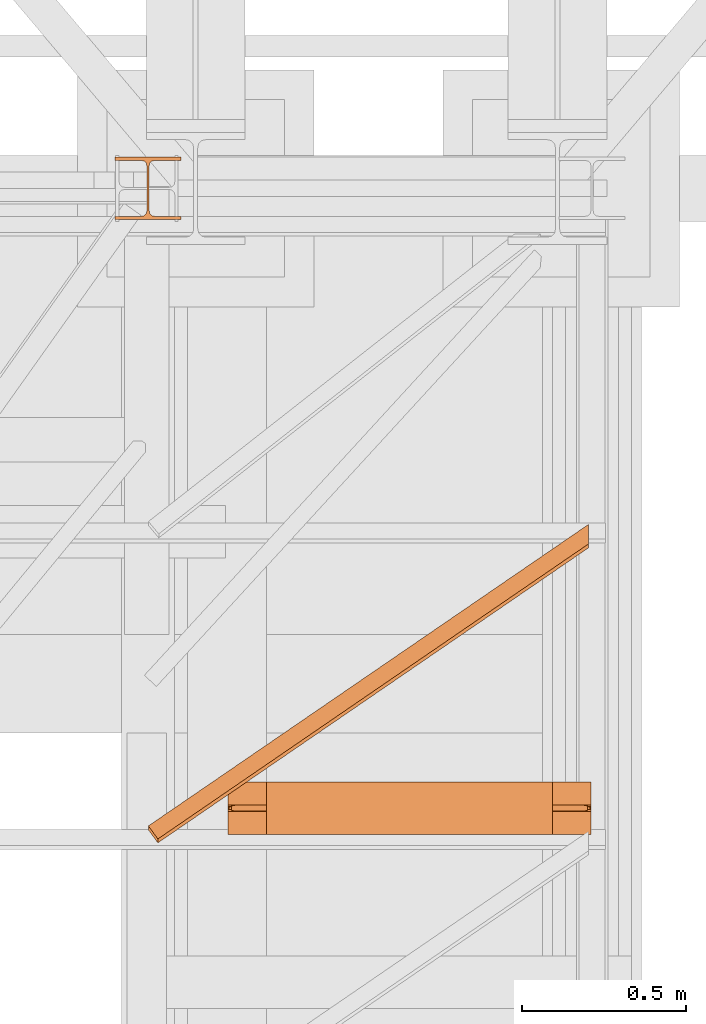
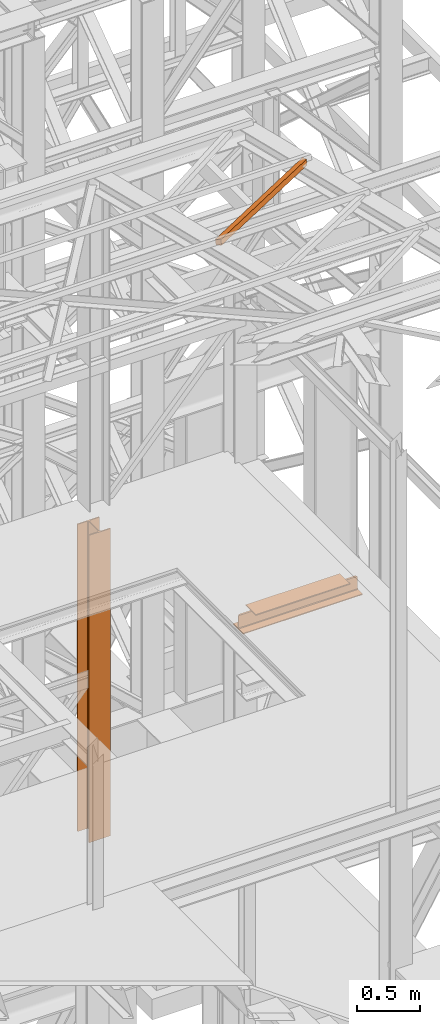
# One storey, part 76 of 208: 3 proxies.
"""IFC2X3 building model written with IfcOpenShell, lengths in millimetres."""

from ifc_helpers import new_model, entity, si_unit, converted_unit, frame, origin, origin_with_axes, place, context, subcontext, project, spatial, faceted_brep, element, save


model = new_model("IFC2X3")

# Units and contexts
model_context = context("Model", 3, precision=1e-05, world=origin())
plan_context = context("Plan", 3, precision=1e-05, world=origin())
body_context = subcontext(model_context, "Body", "Model", "MODEL_VIEW")
ifc_project = project(units=[si_unit("LENGTHUNIT", "METRE", prefix="MILLI"), converted_unit("PLANEANGLEUNIT", "DEGREE", entity("IfcPlaneAngleMeasure", 0.0174532925199433), si_unit("PLANEANGLEUNIT", "RADIAN"), dimensions=[0, 0, 0, 0, 0, 0, 0]), si_unit("AREAUNIT", "SQUARE_METRE"), si_unit("VOLUMEUNIT", "CUBIC_METRE")], contexts=[model_context, plan_context])

# Building, storey
building_placement = place(None, origin())
building = spatial("IfcBuilding", under=ifc_project, at=building_placement, CompositionType="COMPLEX")
storey_placement = place(building_placement, origin_with_axes())
storey = spatial("IfcBuildingStorey", under=building, at=storey_placement, Name="Geschoss", CompositionType="ELEMENT")

# Proxies
proxy_1_placement = place(storey_placement, frame((5349.415251226797, -19252.42762679125, 11987.74979641016), z_axis=(0.0, 0.0, 1.0), x_axis=(1.0, 0.0, 0.0)))
element("IfcBuildingElementProxy", 1, at=proxy_1_placement, inside=storey, context=body_context, shape_type="Brep", body=[
    faceted_brep([(28.82079669527775, 0.00999999999839929, 232.0521250666225), (0.01000000000021828, 39.72174452711624, 222.4128647010039), (0.01000000000021828, 51.51581022395476, 271.0019582749592), (28.82079669527775, 11.80406569683328, 280.6412186405796), (1337.349720073478, 896.5242864318316, 14.44056628674844), (28.82079669527775, 0.00999999999839929, 232.0521250666225), (28.82079669527775, 11.80406569683328, 280.6412186405796), (1337.349720073478, 908.3183521286664, 63.02965986070558), (1337.349720073478, 955.9752131652676, 0.01000000000021828), (0.01000000000021828, 39.72174452711624, 222.4128647010039), (28.82079669527775, 0.00999999999839929, 232.0521250666225), (1337.349720073478, 896.5242864318316, 14.44056628674844), (1337.349720073478, 967.7692788621025, 48.59909357395554), (0.01000000000021828, 51.51581022395476, 271.0019582749592), (0.01000000000021828, 39.72174452711624, 222.4128647010039), (1337.349720073478, 955.9752131652676, 0.01000000000021828), (1337.349720073478, 908.3183521286664, 63.02965986070558), (28.82079669527775, 11.80406569683328, 280.6412186405796), (0.01000000000021828, 51.51581022395476, 271.0019582749592), (1337.349720073478, 967.7692788621025, 48.59909357395554), (1337.349720073478, 896.5242864318316, 14.44056628674844), (1337.349720073478, 908.3183521286664, 63.02965986070558), (1337.349720073478, 967.7692788621025, 48.59909357395554), (1337.349720073478, 955.9752131652676, 0.01000000000021828)], [[[0, 1, 2, 3]], [[4, 5, 6, 7]], [[8, 9, 10, 11]], [[12, 13, 14, 15]], [[16, 17, 18, 19]], [[20, 21, 22, 23]]], orient=[[False], [False], [False], [False], [False], [False]]),
])
proxy_2_placement = place(storey_placement, frame((5592.004968677677, -19226.85030250341, 8332.989992072577), z_axis=(0.0, 0.0, 1.0), x_axis=(1.0, 0.0, 0.0)))
element("IfcBuildingElementProxy", 2, at=proxy_2_placement, inside=storey, context=body_context, shape_type="Brep", body=[
    faceted_brep([(1102.509999701981, 83.01000568851669, 119.0100101923945), (1102.509999701981, 83.01000568851669, 24.01000393390677), (1102.509999701981, 84.56379586666662, 16.24682677745841), (1102.509999701981, 90.24683052509863, 10.5637921190264), (1102.509999701981, 98.01000675022442, 9.010003337860326), (1102.509999701981, 160.0100113248809, 9.010003337860326), (1102.509999701981, 160.0100113248809, 0.01000000000021828), (1102.509999701981, 0.00999999999839929, 0.01000000000021828), (1102.509999701981, 0.00999999999839929, 9.010003337860326), (1102.509999701981, 62.01000457465489, 9.010003337860326), (1102.509999701981, 69.77318079978068, 10.5637921190264), (1102.509999701981, 75.45621545821268, 16.24682677745841), (1102.509999701981, 77.01000563636262, 24.01000393390677), (1102.509999701981, 77.01000563636262, 119.0100101923945), (986.2599950826207, 0.00999999999839929, 152.0100100135805), (116.2600046193611, 0.00999999999839929, 152.0100100135805), (116.260004619362, 160.0100113248809, 152.0100100135805), (986.2599950826207, 160.0100113248809, 152.0100100135805), (986.2599950826207, 160.0100113248809, 152.0100100135805), (116.260004619362, 160.0100113248809, 152.0100100135805), (116.260004619362, 160.0100113248809, 143.0100066757204), (986.2599950826207, 160.0100113248809, 143.0100066757204), (986.2599950826207, 160.0100113248809, 143.0100066757204), (116.260004619362, 160.0100113248809, 143.0100066757204), (116.260004619362, 98.01000675022442, 143.0100066757204), (986.2599950826207, 98.01000675022442, 143.0100066757204), (986.2599950826207, 98.01000675022442, 143.0100066757204), (116.260004619362, 98.01000675022442, 143.0100066757204), (116.260004619362, 90.24683052509863, 141.4562178945544), (986.2599950826207, 90.24683052509863, 141.4562178945544), (986.2599950826207, 90.24683052509863, 141.4562178945544), (116.260004619362, 90.24683052509863, 141.4562178945544), (116.260004619362, 88.80062067717154, 140.0100080466273), (21.01000157952512, 88.80062067717154, 140.0100080466273), (10.14155560940708, 86.62531936377127, 137.834706733227), (8.080032594927616, 84.56379586666662, 135.7731832361224), (1094.439967107056, 84.56379586666662, 135.7731832361224), (1092.378444092576, 86.62531936377127, 137.834706733227), (1081.509998122458, 88.80062067717154, 140.0100080466273), (986.2599950826207, 88.80062067717154, 140.0100080466273), (1094.439967107056, 84.56379586666662, 135.7731832361224), (8.080032594927616, 84.56379586666662, 135.7731832361224), (2.185305970015179, 83.38397287827684, 129.87845523119), (1.811338905195044, 83.01000568851669, 128.0100098049643), (1100.708660796787, 83.01000568851669, 128.0100098049643), (1100.334693731968, 83.38397287827684, 129.87845523119), (1102.509999701981, 83.01000568851669, 24.01000393390677), (1102.509999701981, 83.01000568851669, 119.0100101923945), (1100.708660796787, 83.01000568851669, 128.0100098049643), (1.811338905195044, 83.01000568851669, 128.0100098049643), (0.01000000000112777, 83.01000568851669, 119.0100101923945), (0.01000000000112777, 83.01000568851669, 24.01000393390677), (1102.509999701981, 84.56379586666662, 16.24682677745841), (1102.509999701981, 83.01000568851669, 24.01000393390677), (0.01000000000112777, 83.01000568851669, 24.01000393390677), (0.01000000000112777, 84.56379586666662, 16.24682677745841), (1102.509999701981, 90.24683052509863, 10.5637921190264), (1102.509999701981, 84.56379586666662, 16.24682677745841), (0.01000000000112777, 84.56379586666662, 16.24682677745841), (0.01000000000112777, 90.24683052509863, 10.5637921190264), (1102.509999701981, 98.01000675022442, 9.010003337860326), (1102.509999701981, 90.24683052509863, 10.5637921190264), (0.01000000000112777, 90.24683052509863, 10.5637921190264), (0.01000000000112777, 98.01000675022442, 9.010003337860326), (1102.509999701981, 160.0100113248809, 9.010003337860326), (1102.509999701981, 98.01000675022442, 9.010003337860326), (0.01000000000112777, 98.01000675022442, 9.010003337860326), (0.01000000000203727, 160.0100113248809, 9.010003337860326), (1102.509999701981, 160.0100113248809, 0.01000000000021828), (1102.509999701981, 160.0100113248809, 9.010003337860326), (0.01000000000203727, 160.0100113248809, 9.010003337860326), (0.01000000000203727, 160.0100113248809, 0.01000000000021828), (1102.509999701981, 0.00999999999839929, 0.01000000000021828), (1102.509999701981, 160.0100113248809, 0.01000000000021828), (0.01000000000203727, 160.0100113248809, 0.01000000000021828), (0.009999999999308784, 0.00999999999839929, 0.01000000000021828), (1102.509999701981, 0.00999999999839929, 9.010003337860326), (1102.509999701981, 0.00999999999839929, 0.01000000000021828), (0.009999999999308784, 0.00999999999839929, 0.01000000000021828), (0.01000000000112777, 0.00999999999839929, 9.010003337860326), (1102.509999701981, 62.01000457465489, 9.010003337860326), (1102.509999701981, 0.00999999999839929, 9.010003337860326), (0.01000000000112777, 0.00999999999839929, 9.010003337860326), (0.01000000000112777, 62.01000457465489, 9.010003337860326), (1102.509999701981, 69.77318079978068, 10.5637921190264), (1102.509999701981, 62.01000457465489, 9.010003337860326), (0.01000000000112777, 62.01000457465489, 9.010003337860326), (0.01000000000112777, 69.77318079978068, 10.5637921190264), (1102.509999701981, 75.45621545821268, 16.24682677745841), (1102.509999701981, 69.77318079978068, 10.5637921190264), (0.01000000000112777, 69.77318079978068, 10.5637921190264), (0.01000000000112777, 75.45621545821268, 16.24682677745841), (1102.509999701981, 77.01000563636262, 24.01000393390677), (1102.509999701981, 75.45621545821268, 16.24682677745841), (0.01000000000112777, 75.45621545821268, 16.24682677745841), (0.01000000000112777, 77.01000563636262, 24.01000393390677), (1102.509999701981, 77.01000563636262, 119.0100101923945), (1102.509999701981, 77.01000563636262, 24.01000393390677), (0.01000000000112777, 77.01000563636262, 24.01000393390677), (0.01000000000112777, 77.01000563636262, 119.0100101923945), (1.811338905195044, 77.01000563636262, 128.0100098049643), (1100.708660796787, 77.01000563636262, 128.0100098049643), (1100.708660796787, 77.01000563636262, 128.0100098049643), (1.811338905195044, 77.01000563636262, 128.0100098049643), (2.185305970015179, 76.63603844659883, 129.87845523119), (8.080032594927616, 75.45621545821268, 135.7731832361224), (1094.439967107056, 75.45621545821268, 135.7731832361224), (1100.334693731968, 76.63603844660247, 129.87845523119), (1094.439967107056, 75.45621545821268, 135.7731832361224), (8.080032594927616, 75.45621545821268, 135.7731832361224), (10.14155560940708, 73.39469196110804, 137.834706733227), (21.01000157952512, 71.21939064770777, 140.0100080466273), (116.260004619362, 71.21939064770777, 140.0100080466273), (116.260004619362, 69.77318079978068, 141.4562178945544), (986.2599950826207, 69.77318079978068, 141.4562178945544), (986.2599950826207, 71.21939064770413, 140.0100080466273), (1081.509998122458, 71.21939064770777, 140.0100080466273), (1092.378444092576, 73.3946919611044, 137.834706733227), (986.2599950826207, 69.77318079978068, 141.4562178945544), (116.260004619362, 69.77318079978068, 141.4562178945544), (116.260004619362, 62.01000457465489, 143.0100066757204), (986.2599950826207, 62.01000457465489, 143.0100066757204), (986.2599950826207, 62.01000457465489, 143.0100066757204), (116.260004619362, 62.01000457465489, 143.0100066757204), (116.2600046193611, 0.00999999999839929, 143.0100066757204), (986.2599950826207, 0.00999999999839929, 143.0100066757204), (986.2599950826207, 0.00999999999839929, 143.0100066757204), (116.2600046193611, 0.00999999999839929, 143.0100066757204), (116.2600046193611, 0.00999999999839929, 152.0100100135805), (986.2599950826207, 0.00999999999839929, 152.0100100135805), (0.01000000000112777, 77.01000563636262, 119.0100101923945), (0.01000000000112777, 77.01000563636262, 24.01000393390677), (0.01000000000112777, 75.45621545821268, 16.24682677745841), (0.01000000000112777, 69.77318079978068, 10.5637921190264), (0.01000000000112777, 62.01000457465489, 9.010003337860326), (0.01000000000112777, 0.00999999999839929, 9.010003337860326), (0.009999999999308784, 0.00999999999839929, 0.01000000000021828), (0.01000000000203727, 160.0100113248809, 0.01000000000021828), (0.01000000000203727, 160.0100113248809, 9.010003337860326), (0.01000000000112777, 98.01000675022442, 9.010003337860326), (0.01000000000112777, 90.24683052509863, 10.5637921190264), (0.01000000000112777, 84.56379586666662, 16.24682677745841), (0.01000000000112777, 83.01000568851669, 24.01000393390677), (0.01000000000112777, 83.01000568851669, 119.0100101923945), (0.01000000000112777, 83.01000568851669, 119.0100101923945), (1.811338905195044, 83.01000568851669, 128.0100098049643), (2.185305970015179, 83.38397287827684, 129.87845523119), (2.185305970015179, 76.63603844659883, 129.87845523119), (1.811338905195044, 77.01000563636262, 128.0100098049643), (0.01000000000112777, 77.01000563636262, 119.0100101923945), (2.185305970015179, 83.38397287827684, 129.87845523119), (8.080032594927616, 84.56379586666662, 135.7731832361224), (10.14155560940708, 86.62531936377127, 137.834706733227), (10.14155560940708, 73.39469196110804, 137.834706733227), (8.080032594927616, 75.45621545821268, 135.7731832361224), (2.185305970015179, 76.63603844659883, 129.87845523119), (10.14155560940708, 86.62531936377127, 137.834706733227), (21.01000157952512, 88.80062067717154, 140.0100080466273), (21.01000157952512, 71.21939064770777, 140.0100080466273), (10.14155560940708, 73.39469196110804, 137.834706733227), (21.01000157952512, 88.80062067717154, 140.0100080466273), (116.260004619362, 88.80062067717154, 140.0100080466273), (116.260004619362, 71.21939064770777, 140.0100080466273), (21.01000157952512, 71.21939064770777, 140.0100080466273), (116.260004619362, 88.80062067717154, 140.0100080466273), (116.260004619362, 90.24683052509863, 141.4562178945544), (116.260004619362, 98.01000675022442, 143.0100066757204), (116.260004619362, 160.0100113248809, 143.0100066757204), (116.260004619362, 160.0100113248809, 152.0100100135805), (116.2600046193611, 0.00999999999839929, 152.0100100135805), (116.2600046193611, 0.00999999999839929, 143.0100066757204), (116.260004619362, 62.01000457465489, 143.0100066757204), (116.260004619362, 69.77318079978068, 141.4562178945544), (116.260004619362, 71.21939064770777, 140.0100080466273), (1102.509999701981, 77.01000563636262, 119.0100101923945), (1100.708660796787, 77.01000563636262, 128.0100098049643), (1100.334693731968, 76.63603844660247, 129.87845523119), (1100.334693731968, 83.38397287827684, 129.87845523119), (1100.708660796787, 83.01000568851669, 128.0100098049643), (1102.509999701981, 83.01000568851669, 119.0100101923945), (1100.334693731968, 76.63603844660247, 129.87845523119), (1094.439967107056, 75.45621545821268, 135.7731832361224), (1092.378444092576, 73.3946919611044, 137.834706733227), (1092.378444092576, 86.62531936377127, 137.834706733227), (1094.439967107056, 84.56379586666662, 135.7731832361224), (1100.334693731968, 83.38397287827684, 129.87845523119), (1092.378444092576, 73.3946919611044, 137.834706733227), (1081.509998122458, 71.21939064770777, 140.0100080466273), (1081.509998122458, 88.80062067717154, 140.0100080466273), (1092.378444092576, 86.62531936377127, 137.834706733227), (1081.509998122458, 71.21939064770777, 140.0100080466273), (986.2599950826207, 71.21939064770413, 140.0100080466273), (986.2599950826207, 88.80062067717154, 140.0100080466273), (1081.509998122458, 88.80062067717154, 140.0100080466273), (986.2599950826207, 71.21939064770413, 140.0100080466273), (986.2599950826207, 69.77318079978068, 141.4562178945544), (986.2599950826207, 62.01000457465489, 143.0100066757204), (986.2599950826207, 0.00999999999839929, 143.0100066757204), (986.2599950826207, 0.00999999999839929, 152.0100100135805), (986.2599950826207, 160.0100113248809, 152.0100100135805), (986.2599950826207, 160.0100113248809, 143.0100066757204), (986.2599950826207, 98.01000675022442, 143.0100066757204), (986.2599950826207, 90.24683052509863, 141.4562178945544), (986.2599950826207, 88.80062067717154, 140.0100080466273)], [[[0, 1, 2, 3, 4, 5, 6, 7, 8, 9, 10, 11, 12, 13]], [[14, 15, 16, 17]], [[18, 19, 20, 21]], [[22, 23, 24, 25]], [[26, 27, 28, 29]], [[30, 31, 32, 33, 34, 35, 36, 37, 38, 39]], [[40, 41, 42, 43, 44, 45]], [[46, 47, 48, 49, 50, 51]], [[52, 53, 54, 55]], [[56, 57, 58, 59]], [[60, 61, 62, 63]], [[64, 65, 66, 67]], [[68, 69, 70, 71]], [[72, 73, 74, 75]], [[76, 77, 78, 79]], [[80, 81, 82, 83]], [[84, 85, 86, 87]], [[88, 89, 90, 91]], [[92, 93, 94, 95]], [[96, 97, 98, 99, 100, 101]], [[102, 103, 104, 105, 106, 107]], [[108, 109, 110, 111, 112, 113, 114, 115, 116, 117]], [[118, 119, 120, 121]], [[122, 123, 124, 125]], [[126, 127, 128, 129]], [[130, 131, 132, 133, 134, 135, 136, 137, 138, 139, 140, 141, 142, 143]], [[144, 145, 146, 147, 148, 149]], [[150, 151, 152, 153, 154, 155]], [[156, 157, 158, 159]], [[160, 161, 162, 163]], [[164, 165, 166, 167, 168, 169, 170, 171, 172, 173]], [[174, 175, 176, 177, 178, 179]], [[180, 181, 182, 183, 184, 185]], [[186, 187, 188, 189]], [[190, 191, 192, 193]], [[194, 195, 196, 197, 198, 199, 200, 201, 202, 203]]], orient=[[False], [False], [False], [False], [False], [False], [False], [False], [False], [False], [False], [False], [False], [False], [False], [False], [False], [False], [False], [False], [False], [False], [False], [False], [False], [False], [False], [False], [False], [False], [False], [False], [False], [False], [False], [False]]),
])
proxy_3_placement = place(storey_placement, frame((5248.254967038551, -17357.57438790132, 5284.990005364414), z_axis=(0.0, 0.0, 1.0), x_axis=(1.0, 0.0, 0.0)))
element("IfcBuildingElementProxy", 3, at=proxy_3_placement, inside=storey, context=body_context, shape_type="Brep", body=[
    faceted_brep([(0.01000000000021828, 190.0100125169738, 3000.009996721743), (200.0100029802325, 190.0100125169738, 3000.009996721743), (200.0100029802325, 180.0100146031364, 3000.009996721743), (121.2600035762789, 180.0100071525558, 3000.009996721743), (111.9441915473344, 178.1454621052726, 3000.009996721743), (105.1245498640838, 171.3258190250381, 3000.009996721743), (103.2600015571716, 162.0100079274162, 3000.009996721743), (103.2600015571716, 28.00999713897545, 3000.009996721743), (105.1245498640838, 18.69418604135353, 3000.009996721743), (111.9441915473344, 11.87454296111901, 3000.009996721743), (121.2600035762789, 10.00999791383583, 3000.009996721743), (200.0100029802325, 10.00999791383583, 3000.009996721743), (200.0100029802325, 0.00999999999839929, 3000.009996721743), (0.01000000000021828, 0.00999999999839929, 3000.009996721743), (0.01000000000021828, 10.00999791383583, 3000.009996721743), (78.75999940395377, 10.00999791383583, 3000.009996721743), (88.07581143289826, 11.87454296111901, 3000.009996721743), (94.89545311614893, 18.69418604135353, 3000.009996721743), (96.76000142306111, 28.00999713897545, 3000.009996721743), (96.76000142306111, 162.0100079274162, 3000.009996721743), (94.89545311614893, 171.3258190250381, 3000.009996721743), (88.07581143289826, 178.1454621052726, 3000.009996721743), (78.75999940395377, 180.0100071525558, 3000.009996721743), (0.01000000000021828, 180.0100146031364, 3000.009996721743), (200.0100029802325, 190.0100125169738, 3000.009996721743), (0.01000000000021828, 190.0100125169738, 3000.009996721743), (0.01000000000021828, 190.0100125169738, 0.01000000000021828), (200.0100029802325, 190.0100125169738, 0.01000000000021828), (200.0100029802325, 180.0100146031364, 3000.009996721743), (200.0100029802325, 190.0100125169738, 3000.009996721743), (200.0100029802325, 190.0100125169738, 0.01000000000021828), (200.0100029802325, 180.0100146031364, 0.01000000000021828), (121.2600035762789, 180.0100071525558, 3000.009996721743), (200.0100029802325, 180.0100146031364, 3000.009996721743), (200.0100029802325, 180.0100146031364, 0.01000000000021828), (121.2600035762789, 180.0100071525558, 0.01000000000021828), (111.9441915473344, 178.1454621052726, 3000.009996721743), (121.2600035762789, 180.0100071525558, 3000.009996721743), (121.2600035762789, 180.0100071525558, 0.01000000000021828), (111.9441915473344, 178.1454621052726, 0.01000000000021828), (105.1245498640838, 171.3258190250381, 3000.009996721743), (111.9441915473344, 178.1454621052726, 3000.009996721743), (111.9441915473344, 178.1454621052726, 0.01000000000021828), (105.1245498640838, 171.3258190250381, 0.01000000000021828), (103.2600015571716, 162.0100079274162, 3000.009996721743), (105.1245498640838, 171.3258190250381, 3000.009996721743), (105.1245498640838, 171.3258190250381, 0.01000000000021828), (103.2600015571716, 162.0100079274162, 0.01000000000021828), (103.2600015571716, 28.00999713897545, 3000.009996721743), (103.2600015571716, 162.0100079274162, 3000.009996721743), (103.2600015571716, 162.0100079274162, 0.01000000000021828), (103.2600015571716, 28.00999713897545, 0.01000000000021828), (105.1245498640838, 18.69418604135353, 3000.009996721743), (103.2600015571716, 28.00999713897545, 3000.009996721743), (103.2600015571716, 28.00999713897545, 0.01000000000021828), (105.1245498640838, 18.69418604135353, 0.01000000000021828), (111.9441915473344, 11.87454296111901, 3000.009996721743), (105.1245498640838, 18.69418604135353, 3000.009996721743), (105.1245498640838, 18.69418604135353, 0.01000000000021828), (111.9441915473344, 11.87454296111901, 0.01000000000021828), (121.2600035762789, 10.00999791383583, 3000.009996721743), (111.9441915473344, 11.87454296111901, 3000.009996721743), (111.9441915473344, 11.87454296111901, 0.01000000000021828), (121.2600035762789, 10.00999791383583, 0.01000000000021828), (200.0100029802325, 10.00999791383583, 3000.009996721743), (121.2600035762789, 10.00999791383583, 3000.009996721743), (121.2600035762789, 10.00999791383583, 0.01000000000021828), (200.0100029802325, 10.00999791383583, 0.01000000000021828), (200.0100029802325, 0.00999999999839929, 3000.009996721743), (200.0100029802325, 10.00999791383583, 3000.009996721743), (200.0100029802325, 10.00999791383583, 0.01000000000021828), (200.0100029802325, 0.00999999999839929, 0.01000000000021828), (0.01000000000021828, 0.00999999999839929, 3000.009996721743), (200.0100029802325, 0.00999999999839929, 3000.009996721743), (200.0100029802325, 0.00999999999839929, 0.01000000000021828), (0.01000000000021828, 0.00999999999839929, 0.01000000000021828), (0.01000000000021828, 10.00999791383583, 3000.009996721743), (0.01000000000021828, 0.00999999999839929, 3000.009996721743), (0.01000000000021828, 0.00999999999839929, 0.01000000000021828), (0.01000000000021828, 10.00999791383583, 0.01000000000021828), (78.75999940395377, 10.00999791383583, 3000.009996721743), (0.01000000000021828, 10.00999791383583, 3000.009996721743), (0.01000000000021828, 10.00999791383583, 0.01000000000021828), (78.75999940395377, 10.00999791383583, 0.01000000000021828), (88.07581143289826, 11.87454296111901, 3000.009996721743), (78.75999940395377, 10.00999791383583, 3000.009996721743), (78.75999940395377, 10.00999791383583, 0.01000000000021828), (88.07581143289826, 11.87454296111901, 0.01000000000021828), (94.89545311614893, 18.69418604135353, 3000.009996721743), (88.07581143289826, 11.87454296111901, 3000.009996721743), (88.07581143289826, 11.87454296111901, 0.01000000000021828), (94.89545311614893, 18.69418604135353, 0.01000000000021828), (96.76000142306111, 28.00999713897545, 3000.009996721743), (94.89545311614893, 18.69418604135353, 3000.009996721743), (94.89545311614893, 18.69418604135353, 0.01000000000021828), (96.76000142306111, 28.00999713897545, 0.01000000000021828), (96.76000142306111, 162.0100079274162, 3000.009996721743), (96.76000142306111, 28.00999713897545, 3000.009996721743), (96.76000142306111, 28.00999713897545, 0.01000000000021828), (96.76000142306111, 162.0100079274162, 0.01000000000021828), (94.89545311614893, 171.3258190250381, 3000.009996721743), (96.76000142306111, 162.0100079274162, 3000.009996721743), (96.76000142306111, 162.0100079274162, 0.01000000000021828), (94.89545311614893, 171.3258190250381, 0.01000000000021828), (88.07581143289826, 178.1454621052726, 3000.009996721743), (94.89545311614893, 171.3258190250381, 3000.009996721743), (94.89545311614893, 171.3258190250381, 0.01000000000021828), (88.07581143289826, 178.1454621052726, 0.01000000000021828), (78.75999940395377, 180.0100071525558, 3000.009996721743), (88.07581143289826, 178.1454621052726, 3000.009996721743), (88.07581143289826, 178.1454621052726, 0.01000000000021828), (78.75999940395377, 180.0100071525558, 0.01000000000021828), (0.01000000000021828, 180.0100146031364, 3000.009996721743), (78.75999940395377, 180.0100071525558, 3000.009996721743), (78.75999940395377, 180.0100071525558, 0.01000000000021828), (0.01000000000021828, 180.0100146031364, 0.01000000000021828), (0.01000000000021828, 190.0100125169738, 3000.009996721743), (0.01000000000021828, 180.0100146031364, 3000.009996721743), (0.01000000000021828, 180.0100146031364, 0.01000000000021828), (0.01000000000021828, 190.0100125169738, 0.01000000000021828), (0.01000000000021828, 190.0100125169738, 0.01000000000021828), (0.01000000000021828, 180.0100146031364, 0.01000000000021828), (78.75999940395377, 180.0100071525558, 0.01000000000021828), (88.07581143289826, 178.1454621052726, 0.01000000000021828), (94.89545311614893, 171.3258190250381, 0.01000000000021828), (96.76000142306111, 162.0100079274162, 0.01000000000021828), (96.76000142306111, 28.00999713897545, 0.01000000000021828), (94.89545311614893, 18.69418604135353, 0.01000000000021828), (88.07581143289826, 11.87454296111901, 0.01000000000021828), (78.75999940395377, 10.00999791383583, 0.01000000000021828), (0.01000000000021828, 10.00999791383583, 0.01000000000021828), (0.01000000000021828, 0.00999999999839929, 0.01000000000021828), (200.0100029802325, 0.00999999999839929, 0.01000000000021828), (200.0100029802325, 10.00999791383583, 0.01000000000021828), (121.2600035762789, 10.00999791383583, 0.01000000000021828), (111.9441915473344, 11.87454296111901, 0.01000000000021828), (105.1245498640838, 18.69418604135353, 0.01000000000021828), (103.2600015571716, 28.00999713897545, 0.01000000000021828), (103.2600015571716, 162.0100079274162, 0.01000000000021828), (105.1245498640838, 171.3258190250381, 0.01000000000021828), (111.9441915473344, 178.1454621052726, 0.01000000000021828), (121.2600035762789, 180.0100071525558, 0.01000000000021828), (200.0100029802325, 180.0100146031364, 0.01000000000021828), (200.0100029802325, 190.0100125169738, 0.01000000000021828)], [[[0, 1, 2, 3, 4, 5, 6, 7, 8, 9, 10, 11, 12, 13, 14, 15, 16, 17, 18, 19, 20, 21, 22, 23]], [[24, 25, 26, 27]], [[28, 29, 30, 31]], [[32, 33, 34, 35]], [[36, 37, 38, 39]], [[40, 41, 42, 43]], [[44, 45, 46, 47]], [[48, 49, 50, 51]], [[52, 53, 54, 55]], [[56, 57, 58, 59]], [[60, 61, 62, 63]], [[64, 65, 66, 67]], [[68, 69, 70, 71]], [[72, 73, 74, 75]], [[76, 77, 78, 79]], [[80, 81, 82, 83]], [[84, 85, 86, 87]], [[88, 89, 90, 91]], [[92, 93, 94, 95]], [[96, 97, 98, 99]], [[100, 101, 102, 103]], [[104, 105, 106, 107]], [[108, 109, 110, 111]], [[112, 113, 114, 115]], [[116, 117, 118, 119]], [[120, 121, 122, 123, 124, 125, 126, 127, 128, 129, 130, 131, 132, 133, 134, 135, 136, 137, 138, 139, 140, 141, 142, 143]]], orient=[[False], [False], [False], [False], [False], [False], [False], [False], [False], [False], [False], [False], [False], [False], [False], [False], [False], [False], [False], [False], [False], [False], [False], [False], [False], [False]]),
])

save(model, "model.ifc")
